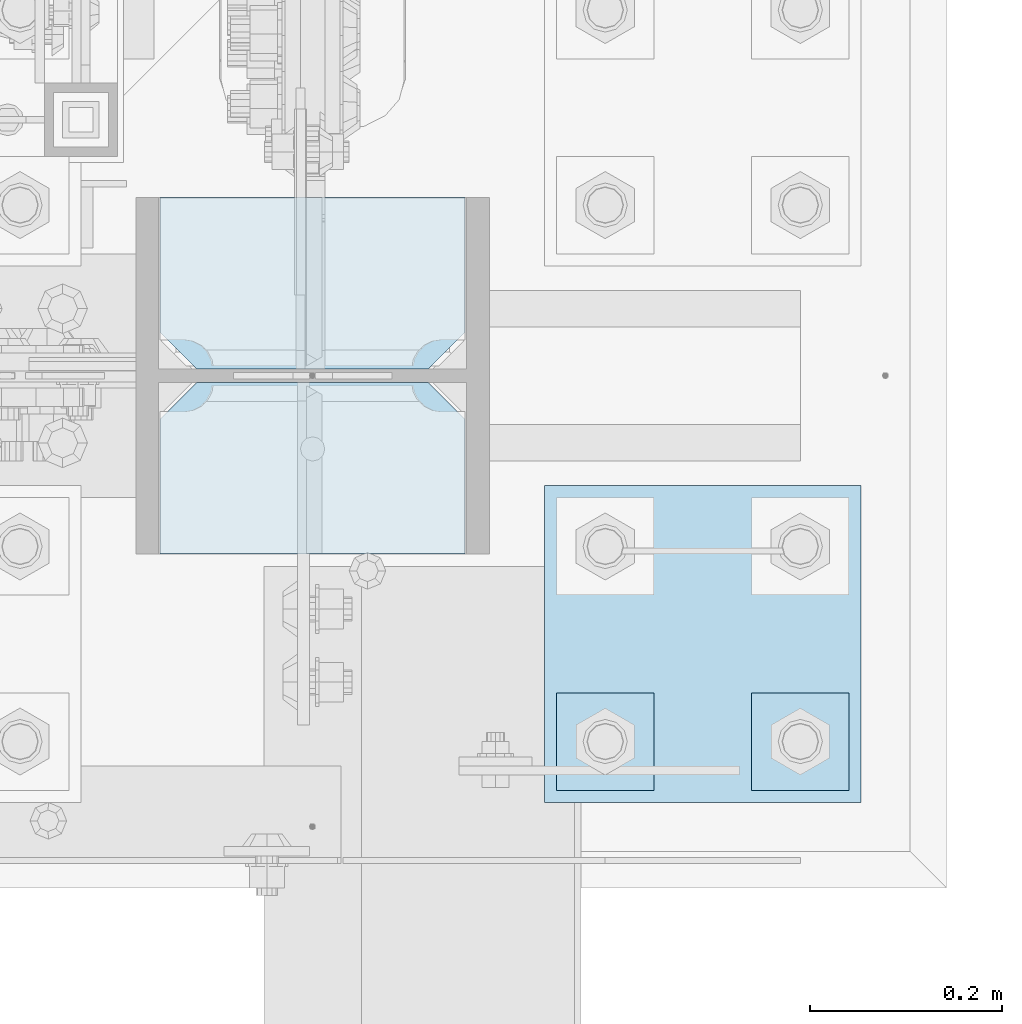
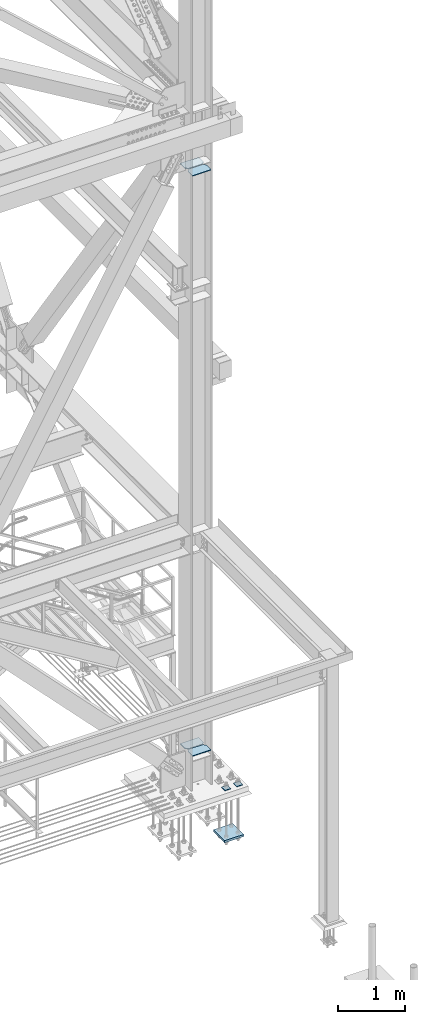
# One storey, part 3564 of 3843: 7 plates, 2 elements without a shape of their own.
"""IFC2X3 building model written with IfcOpenShell, lengths in millimetres."""

from ifc_helpers import new_model, si_unit, frame, origin_with_axes, place, context, subcontext, project, spatial, faceted_brep, material, type_object, element, aggregate, save


model = new_model("IFC2X3")

# Units and contexts
model_context = context("Model", 3, precision=1e-05, world=origin_with_axes())
body_context = subcontext(model_context, "Body", "Model", "MODEL_VIEW")
ifc_project = project(units=[si_unit("LENGTHUNIT", "METRE", prefix="MILLI"), si_unit("AREAUNIT", "SQUARE_METRE"), si_unit("VOLUMEUNIT", "CUBIC_METRE"), si_unit("MASSUNIT", "GRAM", prefix="KILO"), si_unit("TIMEUNIT", "SECOND"), si_unit("PLANEANGLEUNIT", "RADIAN"), si_unit("SOLIDANGLEUNIT", "STERADIAN"), si_unit("THERMODYNAMICTEMPERATUREUNIT", "DEGREE_CELSIUS"), si_unit("LUMINOUSINTENSITYUNIT", "LUMEN")], contexts=[model_context])

# Site, building, storey
site_placement = place(None, origin_with_axes())
site = spatial("IfcSite", under=ifc_project, at=site_placement, CompositionType="ELEMENT")
building_placement = place(site_placement, origin_with_axes())
building = spatial("IfcBuilding", under=site, at=building_placement, Name="Undefined", CompositionType="ELEMENT")
storey_placement = place(building_placement, origin_with_axes())
storey = spatial("IfcBuildingStorey", under=building, at=storey_placement, Name="Undefined", CompositionType="ELEMENT", Elevation=0.0)

# Assembly, plates
assembly_1_placement = place(storey_placement, origin_with_axes())
assembly_1 = element("IfcElementAssembly", 1, at=assembly_1_placement, inside=storey, Name="COLUMN", AssemblyPlace="NOTDEFINED", PredefinedType="RIGID_FRAME")
ifc_material = material(Name="STEEL/A572-50")
plate_type_1 = type_object("IfcPlateType", PredefinedType="NOTDEFINED")
plate_1_placement = place(assembly_1_placement, frame((85807.55, 14812.9625, 30778.3411839474), z_axis=(-1.0, 0.0, 0.0), x_axis=(0.0, 1.0, 0.0)))
plate_1 = element("IfcPlate", 2, at=plate_1_placement, type_object=plate_type_1, material=ifc_material, Name="STIFFENER", context=body_context, shape_type="Brep", body=[
    faceted_brep([(0.0, -6.3499999046162, 0.0), (0.0, -6.34999999999854, 317.5), (0.0, 6.34999999999854, 317.5), (7.27595761418343e-12, 6.3499999046162, 0.0), (140.493751525879, -6.34999999999854, 317.5), (140.493751525879, 6.34999999999854, 317.5), (178.59375, -6.34999999999854, 279.400001525879), (178.59375, 6.34999999999854, 279.400001525879), (178.59375, -6.34999999999854, 38.0999984741211), (178.59375, 6.34999999999854, 38.0999984741211), (140.493751525879, -6.34999999999854, 0.0), (140.493751525879, 6.34999999999854, 0.0)], [[[0, 1, 2, 3]], [[1, 4, 5, 2]], [[4, 6, 7, 5]], [[6, 8, 9, 7]], [[8, 10, 11, 9]], [[10, 0, 3, 11]], [[5, 7, 9, 11, 3, 2]], [[10, 8, 6, 4, 1, 0]]]),
])
plate_2_placement = place(assembly_1_placement, frame((85807.55, 15005.84375, 30778.3411839474), z_axis=(-1.0, 0.0, 0.0), x_axis=(0.0, 1.0, 0.0)))
plate_2 = element("IfcPlate", 3, at=plate_2_placement, type_object=plate_type_1, material=ifc_material, Name="STIFFENER", context=body_context, shape_type="Brep", body=[
    faceted_brep([(0.0, -6.34999999999854, 38.0999984741211), (0.0, -6.34999999999854, 279.400001525879), (0.0, 6.34999999999854, 279.400001525879), (0.0, 6.34999999999854, 38.0999984741211), (38.0999984741211, -6.34999999999854, 317.5), (38.0999984741211, 6.34999999999854, 317.5), (178.59375, -6.34999999999854, 317.5), (178.59375, 6.34999999999854, 317.5), (178.59375, -6.34999999999854, 0.0), (178.59375, 6.34999999999854, 0.0), (38.0999984741211, -6.34999999999854, 0.0), (38.0999984741211, 6.34999999999854, 0.0)], [[[0, 1, 2, 3]], [[1, 4, 5, 2]], [[4, 6, 7, 5]], [[6, 8, 9, 7]], [[8, 10, 11, 9]], [[10, 0, 3, 11]], [[5, 7, 9, 11, 3, 2]], [[10, 8, 6, 4, 1, 0]]]),
])
plate_3_placement = place(assembly_1_placement, frame((85807.55, 14812.9625, 41313.2696352601), z_axis=(-1.0, 0.0, 0.0), x_axis=(0.0, 1.0, 0.0)))
plate_3 = element("IfcPlate", 4, at=plate_3_placement, type_object=plate_type_1, material=ifc_material, Name="STIFFENER", context=body_context, shape_type="Brep", body=[
    faceted_brep([(0.0, -6.3499999046162, 0.0), (0.0, -6.34999999999854, 317.5), (0.0, 6.34999999999854, 317.5), (7.27595761418343e-12, 6.3499999046162, 0.0), (140.493751525879, -6.34999999999854, 317.5), (140.493751525879, 6.34999999999854, 317.5), (178.59375, -6.34999999999854, 279.400001525879), (178.59375, 6.34999999999854, 279.400001525879), (178.59375, -6.34999999999854, 38.0999984741211), (178.59375, 6.34999999999854, 38.0999984741211), (140.493751525879, -6.34999999999854, 0.0), (140.493751525879, 6.34999999999854, 0.0)], [[[0, 1, 2, 3]], [[1, 4, 5, 2]], [[4, 6, 7, 5]], [[6, 8, 9, 7]], [[8, 10, 11, 9]], [[10, 0, 3, 11]], [[5, 7, 9, 11, 3, 2]], [[10, 8, 6, 4, 1, 0]]]),
])
plate_4_placement = place(assembly_1_placement, frame((85807.55, 15005.84375, 41313.2696352601), z_axis=(-1.0, 0.0, 0.0), x_axis=(0.0, 1.0, 0.0)))
plate_4 = element("IfcPlate", 5, at=plate_4_placement, type_object=plate_type_1, material=ifc_material, Name="STIFFENER", context=body_context, shape_type="Brep", body=[
    faceted_brep([(0.0, -6.34999999999854, 38.0999984741211), (0.0, -6.34999999999854, 279.400001525879), (0.0, 6.34999999999854, 279.400001525879), (0.0, 6.34999999999854, 38.0999984741211), (38.0999984741211, -6.34999999999854, 317.5), (38.0999984741211, 6.34999999999854, 317.5), (178.59375, -6.34999999999854, 317.5), (178.59375, 6.34999999999854, 317.5), (178.59375, -6.34999999999854, 0.0), (178.59375, 6.34999999999854, 0.0), (38.0999984741211, -6.34999999999854, 0.0), (38.0999984741211, 6.34999999999854, 0.0)], [[[0, 1, 2, 3]], [[1, 4, 5, 2]], [[4, 6, 7, 5]], [[6, 8, 9, 7]], [[8, 10, 11, 9]], [[10, 0, 3, 11]], [[5, 7, 9, 11, 3, 2]], [[10, 8, 6, 4, 1, 0]]]),
])
aggregate(assembly_1, [plate_1, plate_2, plate_3, plate_4])

assembly_2_placement = place(storey_placement, origin_with_axes())
assembly_2 = element("IfcElementAssembly", 6, at=assembly_2_placement, inside=storey, Name="TEMPLATE", AssemblyPlace="NOTDEFINED", PredefinedType="RIGID_FRAME")
plate_type_2 = type_object("IfcPlateType", PredefinedType="NOTDEFINED")
plate_5_placement = place(assembly_2_placement, frame((86106.0, 14668.5, 30156.15), z_axis=(0.0, -1.0, 0.0), x_axis=(1.0, 0.0, 0.0)))
plate_5 = element("IfcPlate", 7, at=plate_5_placement, type_object=plate_type_2, material=ifc_material, Name="Washer Plate", context=body_context, shape_type="Brep", body=[
    faceted_brep([(0.0, -6.3499999046162, 0.0), (-1.67347025126219e-10, -6.35000000000582, 101.600000000151), (-1.67347025126219e-10, 6.35000000000582, 101.600000000151), (7.27595761418343e-12, 6.3499999046162, 0.0), (101.599998474121, -6.34999999999854, 101.599998474121), (101.599998474121, 6.34999999999854, 101.599998474121), (101.6, -6.34999999999854, 0.0), (101.6, 6.34999999999854, 0.0)], [[[0, 1, 2, 3]], [[1, 4, 5, 2]], [[4, 6, 7, 5]], [[6, 0, 3, 7]], [[5, 7, 3, 2]], [[6, 4, 1, 0]]]),
])
plate_6_placement = place(assembly_2_placement, frame((85902.8, 14668.5, 30156.15), z_axis=(0.0, -1.0, 0.0), x_axis=(1.0, 0.0, 0.0)))
plate_6 = element("IfcPlate", 8, at=plate_6_placement, type_object=plate_type_2, material=ifc_material, Name="Washer Plate", context=body_context, shape_type="Brep", body=[
    faceted_brep([(0.0, -6.3499999046162, 0.0), (-1.67347025126219e-10, -6.35000000000582, 101.600000000151), (-1.67347025126219e-10, 6.35000000000582, 101.600000000151), (7.27595761418343e-12, 6.3499999046162, 0.0), (101.599998474121, -6.34999999999854, 101.599998474121), (101.599998474121, 6.34999999999854, 101.599998474121), (101.6, -6.34999999999854, 0.0), (101.6, 6.34999999999854, 0.0)], [[[0, 1, 2, 3]], [[1, 4, 5, 2]], [[4, 6, 7, 5]], [[6, 0, 3, 7]], [[5, 7, 3, 2]], [[6, 4, 1, 0]]]),
])
plate_type_3 = type_object("IfcPlateType", PredefinedType="NOTDEFINED")
plate_7_placement = place(assembly_2_placement, frame((86220.3, 14884.3999969482, 29241.75), z_axis=(-1.0, 0.0, 0.0), x_axis=(0.0, -1.0, 0.0)))
plate_7 = element("IfcPlate", 9, at=plate_7_placement, type_object=plate_type_3, material=ifc_material, Name="PLATE", context=body_context, shape_type="Brep", body=[
    faceted_brep([(0.0, -19.0500000000029, 0.0), (0.0, -19.0499999999993, 330.200012207031), (0.0, 19.0499999999993, 330.200012207031), (0.0, 19.0500000000029, 0.0), (330.200012207031, -19.0499999999993, 330.200012207031), (330.200012207031, 19.0499999999993, 330.200012207031), (330.200012207031, -19.0499999999993, 0.0), (330.200012207031, 19.0499999999993, 0.0)], [[[0, 1, 2, 3]], [[1, 4, 5, 2]], [[4, 6, 7, 5]], [[6, 0, 3, 7]], [[5, 7, 3, 2]], [[6, 4, 1, 0]]]),
])
aggregate(assembly_2, [plate_7, plate_5, plate_6])

save(model, "model.ifc")
